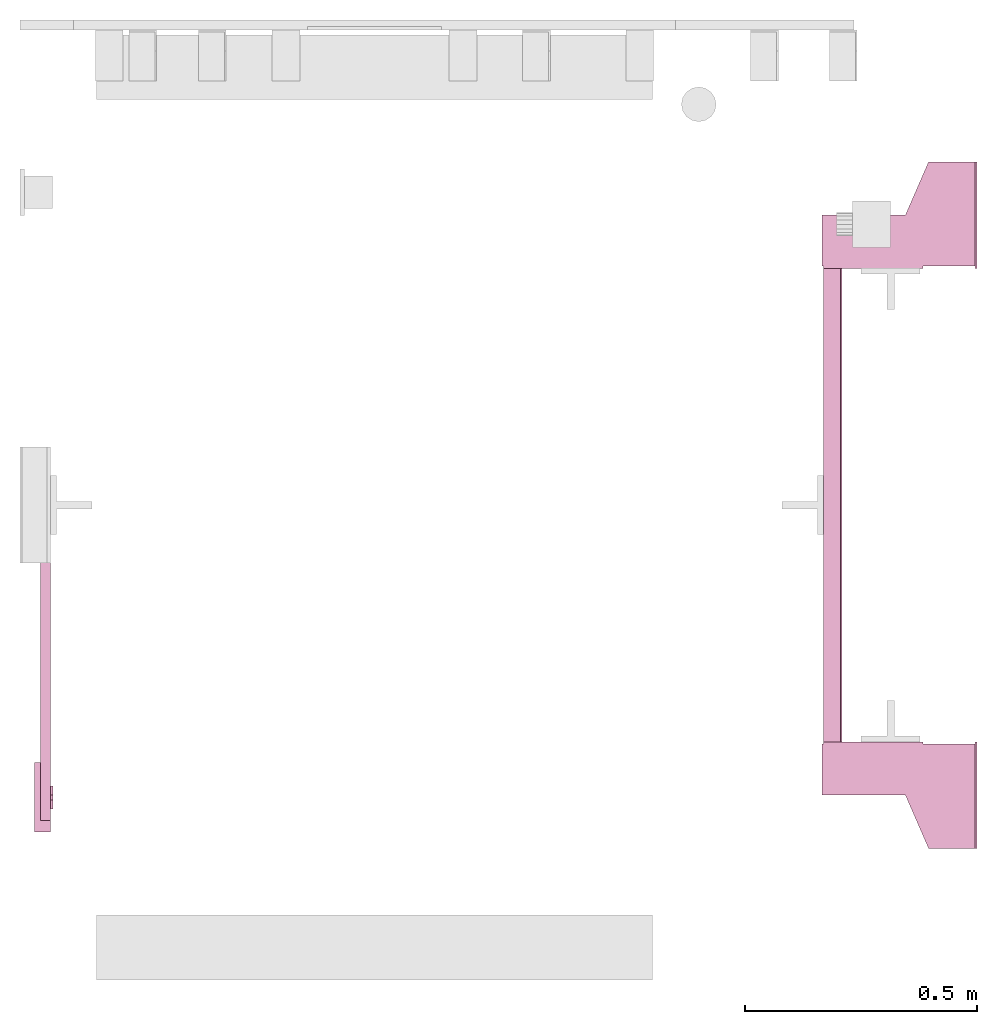
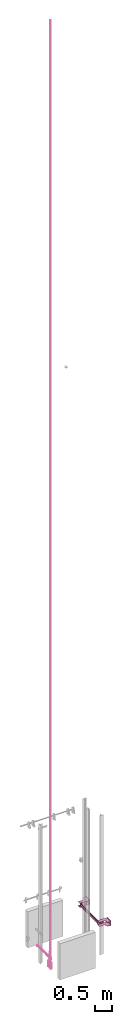
# One storey, part 4 of 5: 2 transport elements.
"""IFC4 building model written with IfcOpenShell, lengths in millimetres."""

from ifc_helpers import new_model, entity, si_unit, converted_unit, frame, origin_with_axes, place, context, subcontext, project, spatial, faceted_brep, element, save


model = new_model("IFC4")

# Units and contexts
context_of_model = context(None, 3, precision=0.01, world=origin_with_axes())
sub_context_1 = subcontext(context_of_model, None, None, "MODEL_VIEW")
sub_context_2 = subcontext(context_of_model, None, None, "MODEL_VIEW")
ifc_project = project(units=[converted_unit("PLANEANGLEUNIT", "degree", entity("IfcPlaneAngleMeasure", 0.017453292519943), si_unit("PLANEANGLEUNIT", "RADIAN"), dimensions=[0, 0, 0, 0, 0, 0, 0]), si_unit("LENGTHUNIT", "METRE", prefix="MILLI"), si_unit("MASSUNIT", "GRAM", prefix="KILO"), converted_unit("TIMEUNIT", "year", entity("IfcTimeMeasure", 31557600.0), si_unit("TIMEUNIT", "SECOND"), dimensions=[0, 0, 1, 0, 0, 0, 0]), si_unit("THERMODYNAMICTEMPERATUREUNIT", "DEGREE_CELSIUS"), si_unit("AREAUNIT", "SQUARE_METRE"), si_unit("FORCEUNIT", "NEWTON"), si_unit("VOLUMEUNIT", "CUBIC_METRE"), si_unit("PRESSUREUNIT", "PASCAL"), si_unit("SOLIDANGLEUNIT", "STERADIAN")], contexts=[context_of_model])

# Site, building, storey
site = spatial("IfcSite", under=ifc_project)
building = spatial("IfcBuilding", under=site, Name="Document")
placement = place(None, origin_with_axes())
storey_placement = place(placement, frame((0.0, 0.0, -24650.0), z_axis=(0.0, 0.0, 1.0), x_axis=(1.0, 0.0, 0.0)))
storey = spatial("IfcBuildingStorey", under=building, at=storey_placement, Name="P11", Elevation=-24650.0)

# Transport elements
transport_element_1_placement = place(storey_placement, frame((2065.0, 1025.0, -550.0), z_axis=(0.0, 0.0, 1.0), x_axis=(0.0, 1.0, 0.0)))
element("IfcTransportElement", 1, at=transport_element_1_placement, inside=storey, PredefinedType="ELEVATOR", context=sub_context_1, shape_type="Brep", body=[
    faceted_brep([(-511.0, 331.0, 32.5), (511.0, 331.0, 32.5), (511.0, 331.0, -32.5), (-511.0, 331.0, -32.5), (511.0, 328.0, -29.5), (511.0, 328.0, 29.5), (-511.0, 328.0, 29.5), (-511.0, 328.0, -29.5), (511.0, 291.0, -32.5), (511.0, 291.0, -29.5), (-511.0, 291.0, -29.5), (-511.0, 291.0, -32.5), (511.0, 291.0, 29.5), (511.0, 291.0, 32.5), (-511.0, 291.0, 32.5), (-511.0, 291.0, 29.5)], [[[0, 1, 2, 3]], [[4, 5, 6, 7]], [[8, 9, 10, 11]], [[12, 13, 14, 15]], [[11, 10, 7, 6, 15, 14, 0, 3]], [[2, 1, 13, 12, 5, 4, 9, 8]], [[2, 8, 11, 3]], [[10, 9, 4, 7]], [[14, 13, 1, 0]], [[5, 12, 15, 6]]]),
    faceted_brep([(-511.0, 291.0, 59.5), (-511.0, 294.0, 59.5), (-511.0, 294.0, 32.5), (-511.0, 291.0, 32.5), (511.0, 291.0, 59.5), (511.0, 291.0, 32.5), (511.0, 294.0, 32.5), (511.0, 294.0, 59.5)], [[[0, 1, 2, 3]], [[4, 5, 6, 7]], [[0, 3, 5, 4]], [[3, 2, 6, 5]], [[2, 1, 7, 6]], [[1, 0, 4, 7]]]),
    faceted_brep([(511.0, 331.0, 75.5), (611.0, 331.0, 75.5), (611.0, 331.0, 72.5), (514.0, 331.0, 72.5), (514.0, 331.0, -72.5), (611.0, 331.0, -72.5), (611.0, 331.0, -75.5), (511.0, 331.0, -75.5), (511.0, 116.0, -75.5), (611.0, 116.0, -75.5), (611.0, 116.0, -72.5), (514.0, 116.0, -72.5), (514.0, 116.0, 72.5), (611.0, 116.0, 72.5), (611.0, 116.0, 75.5), (511.0, 116.0, 75.5)], [[[0, 1, 2, 3, 4, 5, 6, 7]], [[8, 9, 10, 11, 12, 13, 14, 15]], [[8, 15, 0, 7]], [[3, 12, 11, 4]], [[5, 10, 9, 6]], [[1, 14, 13, 2]], [[6, 9, 8, 7]], [[11, 10, 5, 4]], [[15, 14, 1, 0]], [[2, 13, 12, 3]]]),
    faceted_brep([(-611.0, 331.0, -72.5), (-514.0, 331.0, -72.5), (-514.0, 331.0, 72.5), (-611.0, 331.0, 72.5), (-611.0, 331.0, 75.5), (-511.0, 331.0, 75.5), (-511.0, 331.0, -75.5), (-611.0, 331.0, -75.5), (-511.0, 116.0, -75.5), (-511.0, 116.0, 75.5), (-611.0, 116.0, 75.5), (-611.0, 116.0, 72.5), (-514.0, 116.0, 72.5), (-514.0, 116.0, -72.5), (-611.0, 116.0, -72.5), (-611.0, 116.0, -75.5)], [[[0, 1, 2, 3, 4, 5, 6, 7]], [[8, 9, 10, 11, 12, 13, 14, 15]], [[15, 14, 0, 7]], [[13, 12, 2, 1]], [[5, 9, 8, 6]], [[11, 10, 4, 3]], [[6, 8, 15, 7]], [[14, 13, 1, 0]], [[2, 12, 11, 3]], [[10, 9, 5, 4]]]),
    faceted_brep([(-511.0, 291.0, -32.5), (-511.0, 294.0, -32.5), (-511.0, 294.0, -59.5), (-511.0, 291.0, -59.5), (511.0, 291.0, -32.5), (511.0, 291.0, -59.5), (511.0, 294.0, -59.5), (511.0, 294.0, -32.5)], [[[0, 1, 2, 3]], [[4, 5, 6, 7]], [[0, 3, 5, 4]], [[3, 2, 6, 5]], [[2, 1, 7, 6]], [[1, 0, 4, 7]]]),
    faceted_brep([(-626.0, 334.0, -68.5), (-516.0, 334.0, -68.5), (-516.0, 334.0, -72.5), (-626.0, 334.0, -72.5), (-516.0, 4.0, -72.5), (-516.0, 4.0, -68.5), (-741.0, 4.0, -68.5), (-741.0, 4.0, -72.5), (-741.0, 104.0, -68.5), (-626.0, 154.0, -68.5), (-626.0, 154.0, -72.5), (-741.0, 104.0, -72.5)], [[[0, 1, 2, 3]], [[4, 5, 6, 7]], [[8, 9, 10, 11]], [[10, 9, 0, 3]], [[1, 5, 4, 2]], [[7, 6, 8, 11]], [[2, 4, 7, 11, 10, 3]], [[9, 8, 6, 5, 1, 0]]]),
    faceted_brep([(-626.0, 334.0, 72.5), (-516.0, 334.0, 72.5), (-516.0, 334.0, 68.5), (-626.0, 334.0, 68.5), (-516.0, 4.0, 68.5), (-516.0, 4.0, 72.5), (-741.0, 4.0, 72.5), (-741.0, 4.0, 68.5), (-741.0, 104.0, 72.5), (-626.0, 154.0, 72.5), (-626.0, 154.0, 68.5), (-741.0, 104.0, 68.5)], [[[0, 1, 2, 3]], [[4, 5, 6, 7]], [[8, 9, 10, 11]], [[10, 9, 0, 3]], [[1, 5, 4, 2]], [[7, 6, 8, 11]], [[2, 4, 7, 11, 10, 3]], [[9, 8, 6, 5, 1, 0]]]),
    faceted_brep([(741.0, 0.0, -100.0), (741.0, 0.0, 100.0), (511.0, 0.0, 100.0), (511.0, 0.0, -100.0), (741.0, 4.0, -100.0), (511.0, 4.0, -100.0), (511.0, 4.0, 100.0), (741.0, 4.0, 100.0)], [[[0, 1, 2, 3]], [[4, 5, 6, 7]], [[0, 3, 5, 4]], [[3, 2, 6, 5]], [[2, 1, 7, 6]], [[1, 0, 4, 7]]]),
    faceted_brep([(516.0, 334.0, 72.5), (626.0, 334.0, 72.5), (626.0, 334.0, 68.5), (516.0, 334.0, 68.5), (741.0, 4.0, 68.5), (741.0, 4.0, 72.5), (516.0, 4.0, 72.5), (516.0, 4.0, 68.5), (626.0, 154.0, 72.5), (741.0, 104.0, 72.5), (741.0, 104.0, 68.5), (626.0, 154.0, 68.5)], [[[0, 1, 2, 3]], [[4, 5, 6, 7]], [[8, 9, 10, 11]], [[7, 6, 0, 3]], [[1, 8, 11, 2]], [[9, 5, 4, 10]], [[2, 11, 10, 4, 7, 3]], [[6, 5, 9, 8, 1, 0]]]),
    faceted_brep([(516.0, 334.0, -68.5), (626.0, 334.0, -68.5), (626.0, 334.0, -72.5), (516.0, 334.0, -72.5), (741.0, 4.0, -72.5), (741.0, 4.0, -68.5), (516.0, 4.0, -68.5), (516.0, 4.0, -72.5), (626.0, 154.0, -68.5), (741.0, 104.0, -68.5), (741.0, 104.0, -72.5), (626.0, 154.0, -72.5)], [[[0, 1, 2, 3]], [[4, 5, 6, 7]], [[8, 9, 10, 11]], [[7, 6, 0, 3]], [[1, 8, 11, 2]], [[9, 5, 4, 10]], [[2, 11, 10, 4, 7, 3]], [[6, 5, 9, 8, 1, 0]]]),
    faceted_brep([(-511.0, 0.0, -100.0), (-511.0, 0.0, 100.0), (-741.0, 0.0, 100.0), (-741.0, 0.0, -100.0), (-511.0, 4.0, -100.0), (-741.0, 4.0, -100.0), (-741.0, 4.0, 100.0), (-511.0, 4.0, 100.0)], [[[0, 1, 2, 3]], [[4, 5, 6, 7]], [[0, 3, 5, 4]], [[3, 2, 6, 5]], [[2, 1, 7, 6]], [[1, 0, 4, 7]]]),
])
transport_element_2_placement = place(storey_placement, frame((66.0, 1020.0, -1150.0), z_axis=(0.0, 0.0, 1.0), x_axis=(-1.0, 0.0, 0.0)))
element("IfcTransportElement", 2, at=transport_element_2_placement, inside=storey, Name="Shaft0", PredefinedType="ELEVATOR", context=sub_context_2, shape_type="Brep", body=[
    faceted_brep([(8.5e-14, 631.0, 171.0), (8.5e-14, 631.0, 33734.0), (8.5e-14, 621.0, 33734.0), (8.5e-14, 621.0, 171.0), (-4.999999999999915, 631.0, 171.0), (-4.999999999999915, 621.0, 171.0), (-4.999999999999915, 621.0, 33734.0), (-4.999999999999915, 631.0, 33734.0)], [[[0, 1, 2, 3]], [[4, 5, 6, 7]], [[0, 3, 5, 4]], [[3, 2, 6, 5]], [[2, 1, 7, 6]], [[1, 0, 4, 7]]]),
    faceted_brep([(8.5e-14, 651.0, -115.0), (8.5e-14, 651.0, 171.0), (7.1e-14, 601.0, 171.0), (7.1e-14, 601.0, -115.0), (-4.999999999999915, 651.0, -115.0), (-4.999999999999929, 601.0, -115.0), (-4.999999999999929, 601.0, 171.0), (-4.999999999999915, 651.0, 171.0)], [[[0, 1, 2, 3]], [[4, 5, 6, 7]], [[0, 3, 5, 4]], [[3, 2, 6, 5]], [[2, 1, 7, 6]], [[1, 0, 4, 7]]]),
    faceted_brep([(35.000000000000085, 701.0, -115.0), (8.5e-14, 701.0, -115.0), (7.1e-14, 551.0, -115.0), (35.00000000000007, 551.0, -115.0), (35.000000000000085, 701.0, -360.0), (35.00000000000007, 551.0, -360.0), (7.1e-14, 551.0, -360.0), (8.5e-14, 701.0, -360.0)], [[[0, 1, 2, 3]], [[4, 5, 6, 7]], [[0, 3, 5, 4]], [[3, 2, 6, 5]], [[2, 1, 7, 6]], [[1, 0, 4, 7]]]),
    faceted_brep([(22.000000000000085, 676.0, 20.0), (21.999999999999993, -100.0, 20.0), (21.999999999999993, -100.0, -20.0), (22.000000000000085, 676.0, -20.0), (17.999999999999993, -100.0, -16.0), (17.999999999999993, -100.0, 16.0), (18.000000000000085, 676.0, 16.0), (18.000000000000085, 676.0, -16.0), (4.000000000000085, 676.0, -10.0), (3.999999999999993, -100.0, -10.0), (3.999999999999993, -100.0, -16.0), (4.000000000000085, 676.0, -16.0), (-1.4e-14, -100.0, -20.0), (-1.4e-14, -100.0, -10.0), (8.5e-14, 676.0, -10.0), (8.5e-14, 676.0, -20.0), (4.000000000000085, 676.0, 16.0), (3.999999999999993, -100.0, 16.0), (3.999999999999993, -100.0, 10.0), (4.000000000000085, 676.0, 10.0), (-1.4e-14, -100.0, 10.0), (-1.4e-14, -100.0, 20.0), (8.5e-14, 676.0, 20.0), (8.5e-14, 676.0, 10.0)], [[[0, 1, 2, 3]], [[4, 5, 6, 7]], [[8, 9, 10, 11]], [[12, 13, 14, 15]], [[16, 17, 18, 19]], [[20, 21, 22, 23]], [[15, 14, 8, 11, 7, 6, 16, 19, 23, 22, 0, 3]], [[2, 1, 21, 20, 18, 17, 5, 4, 10, 9, 13, 12]], [[2, 12, 15, 3]], [[11, 10, 4, 7]], [[14, 13, 9, 8]], [[22, 21, 1, 0]], [[5, 17, 16, 6]], [[18, 20, 23, 19]]]),
])

save(model, "model.ifc")
